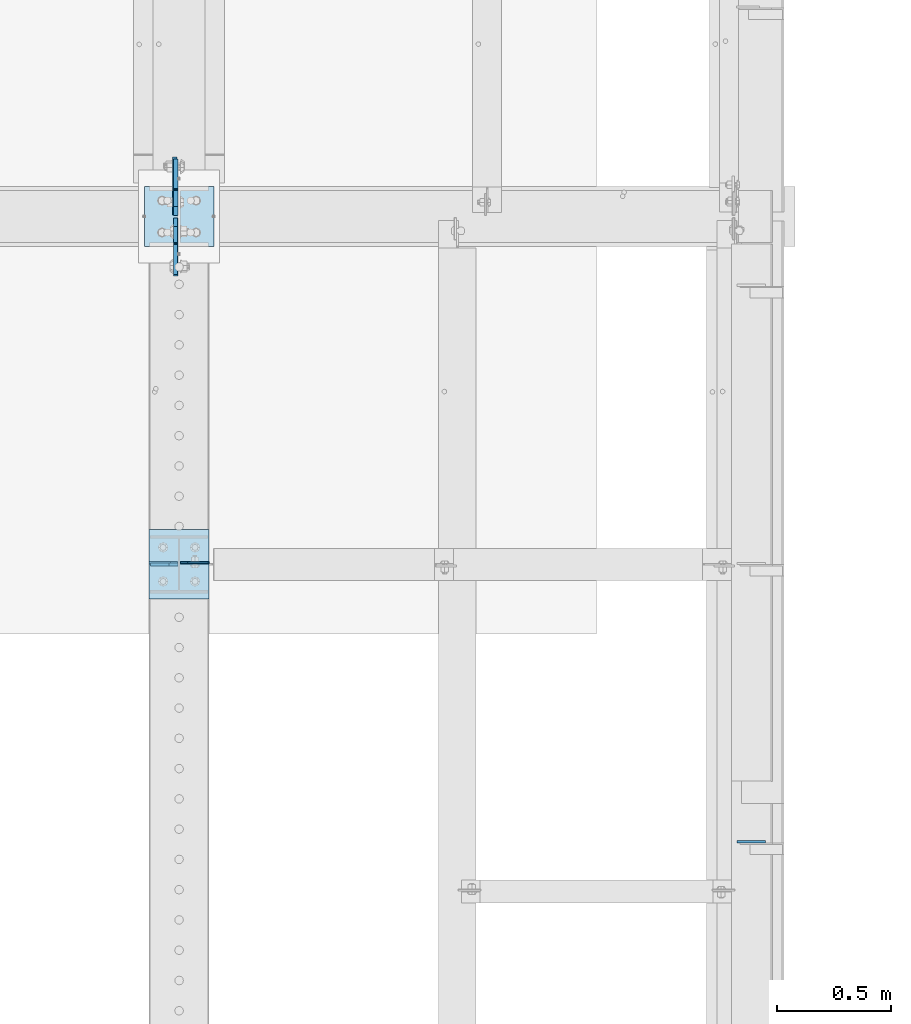
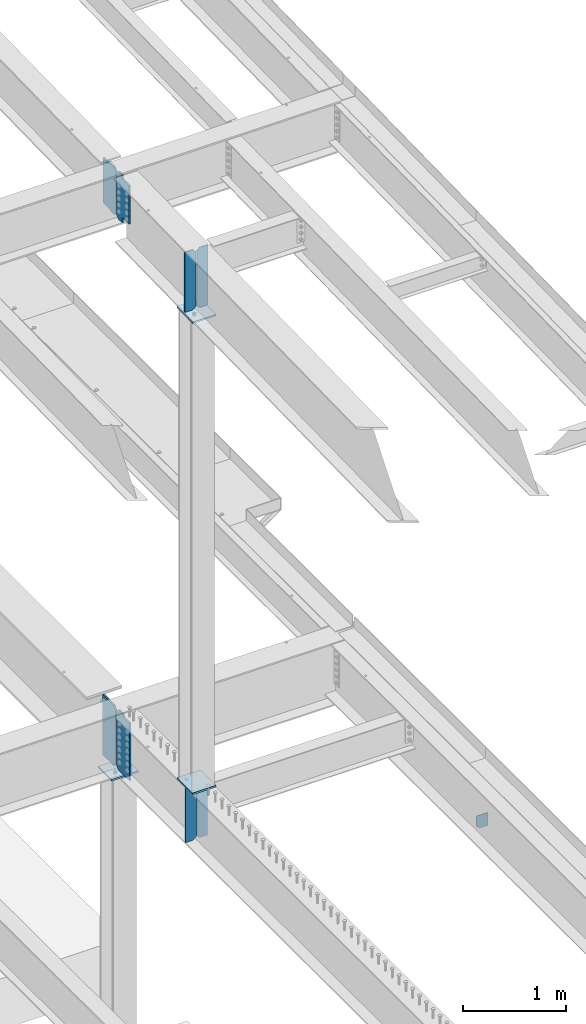
# One storey, part 1589 of 1763: 12 plates, 7 elements without a shape of their own.
"""IFC2X3 building model written with IfcOpenShell, lengths in millimetres."""

from ifc_helpers import new_model, si_unit, frame, origin_with_axes, place, context, subcontext, project, spatial, faceted_brep, material, type_object, element, aggregate, save


model = new_model("IFC2X3")

# Units and contexts
model_context = context("Model", 3, precision=1e-05, world=origin_with_axes())
body_context = subcontext(model_context, "Body", "Model", "MODEL_VIEW")
ifc_project = project(units=[si_unit("LENGTHUNIT", "METRE", prefix="MILLI"), si_unit("AREAUNIT", "SQUARE_METRE"), si_unit("VOLUMEUNIT", "CUBIC_METRE"), si_unit("MASSUNIT", "GRAM", prefix="KILO"), si_unit("TIMEUNIT", "SECOND"), si_unit("PLANEANGLEUNIT", "RADIAN"), si_unit("SOLIDANGLEUNIT", "STERADIAN"), si_unit("THERMODYNAMICTEMPERATUREUNIT", "DEGREE_CELSIUS"), si_unit("LUMINOUSINTENSITYUNIT", "LUMEN")], contexts=[model_context])

# Site, building, storey
site_placement = place(None, origin_with_axes())
site = spatial("IfcSite", under=ifc_project, at=site_placement, CompositionType="ELEMENT")
building_placement = place(site_placement, origin_with_axes())
building = spatial("IfcBuilding", under=site, at=building_placement, Name="Undefined", CompositionType="ELEMENT")
storey_placement = place(building_placement, origin_with_axes())
storey = spatial("IfcBuildingStorey", under=building, at=storey_placement, Name="Undefined", CompositionType="ELEMENT", Elevation=0.0)

# Assembly, plates
assembly_1_placement = place(storey_placement, origin_with_axes())
assembly_1 = element("IfcElementAssembly", 1, at=assembly_1_placement, inside=storey, Name="BEAM", AssemblyPlace="NOTDEFINED", PredefinedType="RIGID_FRAME")
ifc_material_1 = material(Name="STEEL/A36")
plate_type_1 = type_object("IfcPlateType", PredefinedType="NOTDEFINED")
plate_1_placement = place(assembly_1_placement, frame((-24034.4872736984, 43288.7437501095, 10833.2047172586), z_axis=(0.0, 0.0, 1.0), x_axis=(-1.0, 0.0, 0.0)))
plate_1 = element("IfcPlate", 2, at=plate_1_placement, type_object=plate_type_1, material=ifc_material_1, Name="PLATE", context=body_context, shape_type="Brep", body=[
    faceted_brep([(0.0, -6.34999999999854, 31.75), (0.0, -6.34999999999854, 681.915832519531), (0.0, 6.34999999999854, 681.915832519531), (0.0, 6.34999999999854, 31.75), (31.75, -6.34999999999854, 713.665832519531), (31.75, 6.34999999999854, 713.665832519531), (125.412498474121, -6.34999999999854, 713.665832519531), (125.412498474121, 6.34999999999854, 713.665832519531), (125.412498474121, -6.34999999999854, 0.0), (125.412498474121, 6.34999999999854, 0.0), (31.75, -6.34999999999854, 0.0), (31.75, 6.34999999999854, 0.0)], [[[0, 1, 2, 3]], [[1, 4, 5, 2]], [[4, 6, 7, 5]], [[6, 8, 9, 7]], [[8, 10, 11, 9]], [[10, 0, 3, 11]], [[5, 7, 9, 11, 3, 2]], [[10, 8, 6, 4, 1, 0]]]),
])
plate_type_2 = type_object("IfcPlateType", PredefinedType="NOTDEFINED")
plate_2_placement = place(assembly_1_placement, frame((-24021.1872736984, 43288.744750055, 10833.1554500176), z_axis=(0.0, 0.0, 1.0), x_axis=(1.0, 0.0, 0.0)))
plate_2 = element("IfcPlate", 3, at=plate_2_placement, type_object=plate_type_2, material=ifc_material_1, Name="PLATE", context=body_context, shape_type="Brep", body=[
    faceted_brep([(0.0, -3.96899999999732, 31.75), (0.0, -3.96899999999732, 683.601867675781), (0.0, 3.96899999999732, 683.601867675781), (0.0, 3.96899999999732, 31.75), (31.75, -3.96899999999732, 715.351867675781), (31.75, 3.96899999999732, 715.351867675781), (125.412506103516, -3.96899999999732, 715.351867675781), (125.412506103516, 3.96899999999732, 715.351867675781), (125.412506103516, -3.96899999999732, 0.0), (125.412506103516, 3.96899999999732, 0.0), (31.75, -3.96899999999732, 0.0), (31.75, 3.96899999999732, 0.0)], [[[0, 1, 2, 3]], [[1, 4, 5, 2]], [[4, 6, 7, 5]], [[6, 8, 9, 7]], [[8, 10, 11, 9]], [[10, 0, 3, 11]], [[5, 7, 9, 11, 3, 2]], [[10, 8, 6, 4, 1, 0]]]),
])
aggregate(assembly_1, [plate_1, plate_2])

assembly_2_placement = place(storey_placement, origin_with_axes())
assembly_2 = element("IfcElementAssembly", 4, at=assembly_2_placement, inside=storey, Name="BEAM", AssemblyPlace="NOTDEFINED", PredefinedType="RIGID_FRAME")
ifc_material_2 = material(Name="STEEL/A572-50")
plate_type_3 = type_object("IfcPlateType", PredefinedType="NOTDEFINED")
plate_3_placement = place(assembly_2_placement, frame((-24046.0935240798, 44811.95, 4462.4625), z_axis=(0.0, 0.0, 1.0), x_axis=(0.0, 1.0, 0.0)))
plate_3 = element("IfcPlate", 5, at=plate_3_placement, type_object=plate_type_3, material=ifc_material_2, Name="PLATE", context=body_context, shape_type="Brep", body=[
    faceted_brep([(0.0, -9.52500000000146, 38.0999984741211), (0.0, -9.52500000000146, 677.862525939941), (0.0, 9.52500000000146, 677.862525939941), (0.0, 9.52500000000146, 38.0999984741211), (38.0999984741211, -9.52500000000146, 715.962524414062), (38.0999984741211, 9.52500000000146, 715.962524414062), (254.0, -9.52500000000146, 715.962524414062), (254.0, 9.52500000000146, 715.962524414062), (254.0, -9.52500000000146, 0.0), (254.0, 9.52500000000146, 0.0), (38.0999984741211, -9.52500000000146, 0.0), (38.0999984741211, 9.52500000000146, 0.0)], [[[0, 1, 2, 3]], [[1, 4, 5, 2]], [[4, 6, 7, 5]], [[6, 8, 9, 7]], [[8, 10, 11, 9]], [[10, 0, 3, 11]], [[5, 7, 9, 11, 3, 2]], [[10, 8, 6, 4, 1, 0]]]),
])
plate_4_placement = place(assembly_2_placement, frame((-24042.9184846011, 44799.25, 4462.4625), z_axis=(0.0, 0.0, 1.0), x_axis=(0.0, -1.0, 0.0)))
plate_4 = element("IfcPlate", 6, at=plate_4_placement, type_object=plate_type_3, material=ifc_material_2, Name="PLATE", context=body_context, shape_type="Brep", body=[
    faceted_brep([(125.412994384773, -9.52500000000146, 715.962524414062), (125.412994384773, -9.52500000000146, 696.912487602234), (125.412994384773, 9.52500000000146, 696.912487602234), (125.412994384773, 9.52500000000146, 715.962524414062), (126.37972430736, -9.52500000000146, 692.052408084189), (126.37972430736, 9.52500000000146, 692.052408084189), (129.132738207838, -9.52500000000146, 687.932231616035), (129.132738207838, 9.52500000000146, 687.932231616035), (133.252914675992, -9.52500000000146, 685.179217715557), (133.252914675992, 9.52500000000146, 685.179217715557), (138.112994194038, -9.52500000000146, 684.212487792969), (138.112994194038, 9.52500000000146, 684.212487792969), (254.000000000007, -9.52500000000146, 684.212487792969), (254.0, 9.52500000000146, 684.212487792969), (0.0, -9.52500000000146, 677.862525939941), (38.0999984741211, -9.52500000000146, 715.962524414062), (38.0999984741211, 9.52500000000146, 715.962524414062), (0.0, 9.52500000000146, 677.862525939941), (0.0, -9.52500000000146, 38.0999984741211), (0.0, 9.52500000000146, 38.0999984741211), (38.0999984741211, -9.52500000000146, 0.0), (38.0999984741211, 9.52500000000146, 0.0), (254.0, -9.52500000000146, 0.0), (254.0, 9.52500000000146, 0.0)], [[[0, 1, 2, 3]], [[4, 5, 2, 1]], [[6, 7, 5, 4]], [[8, 9, 7, 6]], [[10, 11, 9, 8]], [[12, 13, 11, 10]], [[14, 15, 16, 17]], [[18, 14, 17, 19]], [[20, 18, 19, 21]], [[22, 20, 21, 23]], [[8, 6, 4, 1, 0, 15, 14, 18, 20, 22, 12, 10]], [[16, 15, 0, 3]], [[23, 21, 19, 17, 16, 3, 2, 5, 7, 9, 11, 13]], [[22, 23, 13, 12]]]),
])
aggregate(assembly_2, [plate_3, plate_4])

# Assembly, plate
assembly_3_placement = place(storey_placement, origin_with_axes())
assembly_3 = element("IfcElementAssembly", 7, at=assembly_3_placement, inside=storey, Name="COLUMN", AssemblyPlace="NOTDEFINED", PredefinedType="RIGID_FRAME")
plate_type_4 = type_object("IfcPlateType", PredefinedType="NOTDEFINED")
plate_5_placement = place(assembly_3_placement, frame((-23875.4372736984, 44937.3625, 4435.475), z_axis=(-1.0, 0.0, 0.0), x_axis=(0.0, -1.0, 0.0)))
plate_5 = element("IfcPlate", 8, at=plate_5_placement, type_object=plate_type_4, material=ifc_material_2, Name="PLATE", context=body_context, shape_type="Brep", body=[
    faceted_brep([(0.0, -9.52500000000146, 0.0), (0.0, -9.52499999999998, 304.799987792969), (0.0, 9.52499999999998, 304.799987792969), (0.0, 9.52500000000146, 0.0), (263.524993896484, -9.52499999999964, 304.799987792969), (263.524993896484, 9.52499999999964, 304.799987792969), (263.524993896484, -9.52499999999964, 0.0), (263.524993896484, 9.52499999999964, 0.0)], [[[0, 1, 2, 3]], [[1, 4, 5, 2]], [[4, 6, 7, 5]], [[6, 0, 3, 7]], [[5, 7, 3, 2]], [[6, 4, 1, 0]]]),
])
aggregate(assembly_3, [plate_5])

# Assembly, plates
assembly_4_placement = place(storey_placement, origin_with_axes())
assembly_4 = element("IfcElementAssembly", 9, at=assembly_4_placement, inside=storey, Name="COLUMN", AssemblyPlace="NOTDEFINED", PredefinedType="RIGID_FRAME")
plate_6_placement = place(assembly_4_placement, frame((-23896.0747736984, 43129.4296345901, 10802.4842480928), z_axis=(0.0, 0.999786037781472, 0.0206852279954825), x_axis=(-1.0, 0.0, 0.0)))
plate_6 = element("IfcPlate", 10, at=plate_6_placement, type_object=plate_type_4, material=ifc_material_2, Name="PLATE", context=body_context, shape_type="Brep", body=[
    faceted_brep([(0.0, -9.52500000000146, 0.0), (0.0, -9.52499999999998, 304.799987792969), (0.0, 9.52499999999998, 304.799987792969), (0.0, 9.52500000000146, 0.0), (263.524993896484, -9.52499999999964, 304.799987792969), (263.524993896484, 9.52499999999964, 304.799987792969), (263.524993896484, -9.52499999999964, 0.0), (263.524993896484, 9.52499999999964, 0.0)], [[[0, 1, 2, 3]], [[1, 4, 5, 2]], [[4, 6, 7, 5]], [[6, 0, 3, 7]], [[5, 7, 3, 2]], [[6, 4, 1, 0]]]),
])
plate_7_placement = place(assembly_4_placement, frame((-24159.5997736984, 43129.2, 5203.825), z_axis=(0.0, 1.0, 0.0), x_axis=(1.0, 0.0, 0.0)))
plate_7 = element("IfcPlate", 11, at=plate_7_placement, type_object=plate_type_4, material=ifc_material_2, Name="PLATE", context=body_context, shape_type="Brep", body=[
    faceted_brep([(0.0, -9.52500000000146, 0.0), (0.0, -9.52499999999998, 304.799987792969), (0.0, 9.52499999999998, 304.799987792969), (0.0, 9.52500000000146, 0.0), (263.524993896484, -9.52499999999964, 304.799987792969), (263.524993896484, 9.52499999999964, 304.799987792969), (263.524993896484, -9.52499999999964, 0.0), (263.524993896484, 9.52499999999964, 0.0)], [[[0, 1, 2, 3]], [[1, 4, 5, 2]], [[4, 6, 7, 5]], [[6, 0, 3, 7]], [[5, 7, 3, 2]], [[6, 4, 1, 0]]]),
])
aggregate(assembly_4, [plate_6, plate_7])

# Assembly, plate
assembly_5_placement = place(storey_placement, origin_with_axes())
assembly_5 = element("IfcElementAssembly", 12, at=assembly_5_placement, inside=storey, Name="BEAM", AssemblyPlace="NOTDEFINED", PredefinedType="RIGID_FRAME")
plate_type_5 = type_object("IfcPlateType", PredefinedType="NOTDEFINED")
plate_8_placement = place(assembly_5_placement, frame((-24154.0434828743, 43281.6, 5176.8375), z_axis=(0.0, 0.0, -1.0), x_axis=(1.0, 0.0, 0.0)))
plate_8 = element("IfcPlate", 13, at=plate_8_placement, type_object=plate_type_5, material=ifc_material_2, Name="PLATE", context=body_context, shape_type="Brep", body=[
    faceted_brep([(0.0, -6.34999999999491, 1.45519152283669e-11), (0.0, -6.35000000000036, 644.525024414062), (0.0, 6.35000000000036, 644.525024414062), (0.0, 6.34999999999491, -2.91038304567337e-11), (82.5500030517578, -6.34999999999854, 644.525024414062), (82.5500030517578, 6.34999999999854, 644.525024414062), (120.650001525879, -6.34999999999854, 606.425025939941), (120.650001525879, 6.34999999999854, 606.425025939941), (120.650001525879, -6.34999999999854, 38.0999984741211), (120.650001525879, 6.34999999999854, 38.0999984741211), (82.5500030517578, -6.34999999999854, 0.0), (82.5500030517578, 6.34999999999854, 0.0)], [[[0, 1, 2, 3]], [[1, 4, 5, 2]], [[4, 6, 7, 5]], [[6, 8, 9, 7]], [[8, 10, 11, 9]], [[10, 0, 3, 11]], [[5, 7, 9, 11, 3, 2]], [[10, 8, 6, 4, 1, 0]]]),
])

assembly_6_placement = place(storey_placement, origin_with_axes())
assembly_6 = element("IfcElementAssembly", 14, at=assembly_6_placement, inside=storey, Name="BEAM", AssemblyPlace="NOTDEFINED", PredefinedType="RIGID_FRAME")
plate_type_6 = type_object("IfcPlateType", PredefinedType="NOTDEFINED")
plate_9_placement = place(assembly_6_placement, frame((-21583.8810236986, 42066.5572382717, 4530.72499999994), z_axis=(0.0, 0.0, 1.0), x_axis=(1.0, 0.0, 0.0)))
plate_9 = element("IfcPlate", 15, at=plate_9_placement, type_object=plate_type_6, material=ifc_material_1, Name="PLATE", context=body_context, shape_type="Brep", body=[
    faceted_brep([(0.0, -4.76250000000073, 31.75), (-3.05175672110636e-06, -4.7625000002663, 152.399993896484), (-3.05175490211695e-06, 4.76249999972788, 152.399993896484), (0.0, 4.76250000000073, 31.75), (126.242965698038, -4.76250000000073, 152.399993896538), (126.242965698038, 4.76250000000073, 152.399993896538), (126.242965698242, -4.76250000000073, 1.02772901300341e-10), (126.242965698242, 4.76250000000073, 1.02772901300341e-10), (31.75, -4.76250000000073, 0.0), (31.75, 4.76250000000073, 0.0)], [[[0, 1, 2, 3]], [[1, 4, 5, 2]], [[4, 6, 7, 5]], [[6, 8, 9, 7]], [[8, 0, 3, 9]], [[5, 7, 9, 3, 2]], [[8, 6, 4, 1, 0]]]),
])
aggregate(assembly_6, [plate_9])

# Assembly, plates
assembly_7_placement = place(storey_placement, origin_with_axes())
assembly_7 = element("IfcElementAssembly", 16, at=assembly_7_placement, inside=storey, Name="BEAM", AssemblyPlace="NOTDEFINED", PredefinedType="RIGID_FRAME")
plate_type_7 = type_object("IfcPlateType", PredefinedType="NOTDEFINED")
plate_10_placement = place(assembly_7_placement, frame((-24042.9185240798, 44811.1562499732, 11007.7838409684), z_axis=(0.0, 0.0, 1.0), x_axis=(0.0, 1.0, 0.0)))
plate_10 = element("IfcPlate", 17, at=plate_10_placement, type_object=plate_type_7, material=ifc_material_2, Name="PLATE", context=body_context, shape_type="Brep", body=[
    faceted_brep([(108.743749854828, -9.52500000000146, 0.0), (108.743749854828, 9.52500000000146, 0.0), (108.743746948239, 9.52500000000509, 4.62016315496112), (108.743746948239, -9.52500000000146, 4.62016315496112), (109.71047687083, 9.52500000000509, 9.48024267300752), (109.71047687083, -9.52500000000146, 9.48024267300752), (112.463490771304, 9.52500000000509, 13.6004191411612), (112.463490771304, -9.52500000000146, 13.6004191411612), (116.583667239458, 9.52500000000509, 16.3534330416387), (116.583667239458, -9.52500000000146, 16.3534330416387), (121.443746757504, 9.52500000000509, 17.3201629642263), (121.443746757504, -9.52500000000146, 17.3201629642263), (247.649993896484, -9.52500000000146, 17.3201629642263), (247.649993896484, 9.52500000000146, 17.3201629642263), (38.0999984741211, -9.52500000000146, 0.0), (0.0, -9.52500000000146, 38.0999984741211), (0.0, 9.52500000000146, 38.0999984741211), (38.0999984741211, 9.52500000000146, 0.0), (8.70204530656338e-09, -9.52500000000146, 531.812477111816), (8.70204530656338e-09, 9.52500000000146, 531.812477111816), (38.0999984834489, -9.52500000000146, 569.912475585938), (38.0999984834489, 9.52500000000146, 569.912475585938), (108.743746948239, -9.52500000000146, 569.912475585938), (108.743746948239, 9.52500000000146, 569.912475585938), (108.743746948239, -9.52500000000146, 564.264558475925), (108.743746948239, 9.52500000000146, 564.264558475925), (109.71047687083, -9.52500000000146, 559.404478957878), (109.71047687083, 9.52500000000146, 559.404478957878), (112.463490771304, -9.52500000000146, 555.284302489725), (112.463490771304, 9.52500000000146, 555.284302489725), (116.583667239458, -9.52500000000146, 552.531288589247), (116.583667239458, 9.52500000000146, 552.531288589247), (121.443746757504, -9.52500000000146, 551.56455866666), (121.443746757504, 9.52500000000146, 551.56455866666), (247.649993896484, -9.52500000000146, 551.56455866666), (247.649993896484, 9.52500000000146, 551.56455866666)], [[[0, 1, 2, 3]], [[3, 2, 4, 5]], [[5, 4, 6, 7]], [[7, 6, 8, 9]], [[9, 8, 10, 11]], [[12, 11, 10, 13]], [[14, 15, 16, 17]], [[15, 18, 19, 16]], [[18, 20, 21, 19]], [[21, 20, 22, 23]], [[22, 24, 25, 23]], [[26, 27, 25, 24]], [[28, 29, 27, 26]], [[30, 31, 29, 28]], [[32, 33, 31, 30]], [[34, 35, 33, 32]], [[35, 34, 12, 13]], [[8, 6, 4, 2, 1, 17, 16, 19, 21, 23, 25, 27, 29, 31, 33, 35, 13, 10]], [[14, 17, 1, 0]], [[34, 32, 30, 28, 26, 24, 22, 20, 18, 15, 14, 0, 3, 5, 7, 9, 11, 12]]]),
])
plate_11_placement = place(assembly_7_placement, frame((-24043.7122740798, 44800.0437499732, 11007.7838409688), z_axis=(0.0, 0.0, 1.0), x_axis=(0.0, -1.0, 0.0)))
plate_11 = element("IfcPlate", 18, at=plate_11_placement, type_object=plate_type_7, material=ifc_material_2, Name="PLATE", context=body_context, shape_type="Brep", body=[
    faceted_brep([(108.743749854828, -9.52500000000146, 0.0), (108.743749854828, 9.52500000000146, 0.0), (108.74374729838, 9.52500000000146, 53.6698287952804), (108.74374729838, -9.52500000000146, 53.6698287952804), (109.710474827873, 9.52500000000146, 58.5299059377758), (109.710474827873, -9.52500000000146, 58.5299059377758), (112.46348468322, 9.52500000000146, 62.6500817451433), (112.46348468322, -9.52500000000146, 62.6500817451433), (116.583656543145, 9.52500000000146, 65.4030975082514), (116.583656543145, -9.52500000000146, 65.4030975082514), (121.443732299478, 9.52500000000146, 66.3698320064232), (121.443732299478, -9.52500000000146, 66.3698320064232), (247.649993896484, -9.52500000000146, 66.3699791624877), (247.649993896484, 9.52500000000146, 66.3699791627168), (38.0999984741211, -9.52500000000146, 0.0), (0.0, -9.52500000000146, 38.0999984741211), (0.0, 9.52500000000146, 38.0999984741211), (38.0999984741211, 9.52500000000146, 0.0), (8.70204530656338e-09, -9.52500000000146, 531.812477111816), (8.70204530656338e-09, 9.52500000000146, 531.812477111816), (38.0999984834489, -9.52500000000146, 569.912475585938), (38.0999984834489, 9.52500000000146, 569.912475585938), (108.743746948239, -9.52500000000146, 569.912475585938), (108.743746948239, 9.52500000000146, 569.912475585938), (108.743743896484, -9.52499999999418, 536.122015421728), (108.743743896484, 9.52500000000146, 536.122015421728), (109.710473819076, -9.52499999999418, 531.261935903682), (109.710473819076, 9.52500000000146, 531.261935903682), (112.463487719549, -9.52499999999418, 527.141759435528), (112.463487719549, 9.52500000000146, 527.141759435528), (116.583664187703, -9.52499999999418, 524.38874553505), (116.583664187703, 9.52500000000146, 524.38874553505), (121.44374370575, -9.52499999999418, 523.422015612463), (121.44374370575, 9.52500000000146, 523.422015612463), (247.649993896484, -9.52499999999418, 523.422015612463), (247.649993896484, 9.52500000000146, 523.422015612463)], [[[0, 1, 2, 3]], [[3, 2, 4, 5]], [[5, 4, 6, 7]], [[7, 6, 8, 9]], [[9, 8, 10, 11]], [[12, 11, 10, 13]], [[14, 15, 16, 17]], [[15, 18, 19, 16]], [[18, 20, 21, 19]], [[21, 20, 22, 23]], [[22, 24, 25, 23]], [[26, 27, 25, 24]], [[28, 29, 27, 26]], [[30, 31, 29, 28]], [[32, 33, 31, 30]], [[34, 35, 33, 32]], [[35, 34, 12, 13]], [[8, 6, 4, 2, 1, 17, 16, 19, 21, 23, 25, 27, 29, 31, 33, 35, 13, 10]], [[14, 17, 1, 0]], [[34, 32, 30, 28, 26, 24, 22, 20, 18, 15, 14, 0, 3, 5, 7, 9, 11, 12]]]),
])
aggregate(assembly_7, [plate_10, plate_11])

# Plate
plate_type_8 = type_object("IfcPlateType", PredefinedType="NOTDEFINED")
plate_12_placement = place(assembly_5_placement, frame((-24022.2810236984, 43288.7447500649, 4532.3125), z_axis=(0.0, 0.0, 1.0), x_axis=(1.0, 0.0, 0.0)))
plate_12 = element("IfcPlate", 19, at=plate_12_placement, type_object=plate_type_8, material=ifc_material_1, Name="PLATE", context=body_context, shape_type="Brep", body=[
    faceted_brep([(0.0, -3.96899999999732, 31.75), (0.0, -3.96899999999732, 614.362487792969), (0.0, 3.96899999999732, 614.362487792969), (0.0, 3.96899999999732, 31.75), (31.75, -3.96899999999732, 646.112487792969), (31.75, 3.96899999999732, 646.112487792969), (120.650001525879, -3.96899999999732, 646.112487792969), (120.650001525879, 3.96899999999732, 646.112487792969), (120.650001525879, -3.96899999999732, 0.0), (120.650001525879, 3.96899999999732, 0.0), (31.75, -3.96899999999732, 0.0), (31.75, 3.96899999999732, 0.0)], [[[0, 1, 2, 3]], [[1, 4, 5, 2]], [[4, 6, 7, 5]], [[6, 8, 9, 7]], [[8, 10, 11, 9]], [[10, 0, 3, 11]], [[5, 7, 9, 11, 3, 2]], [[10, 8, 6, 4, 1, 0]]]),
])

aggregate(assembly_5, [plate_12, plate_8])

save(model, "model.ifc")
